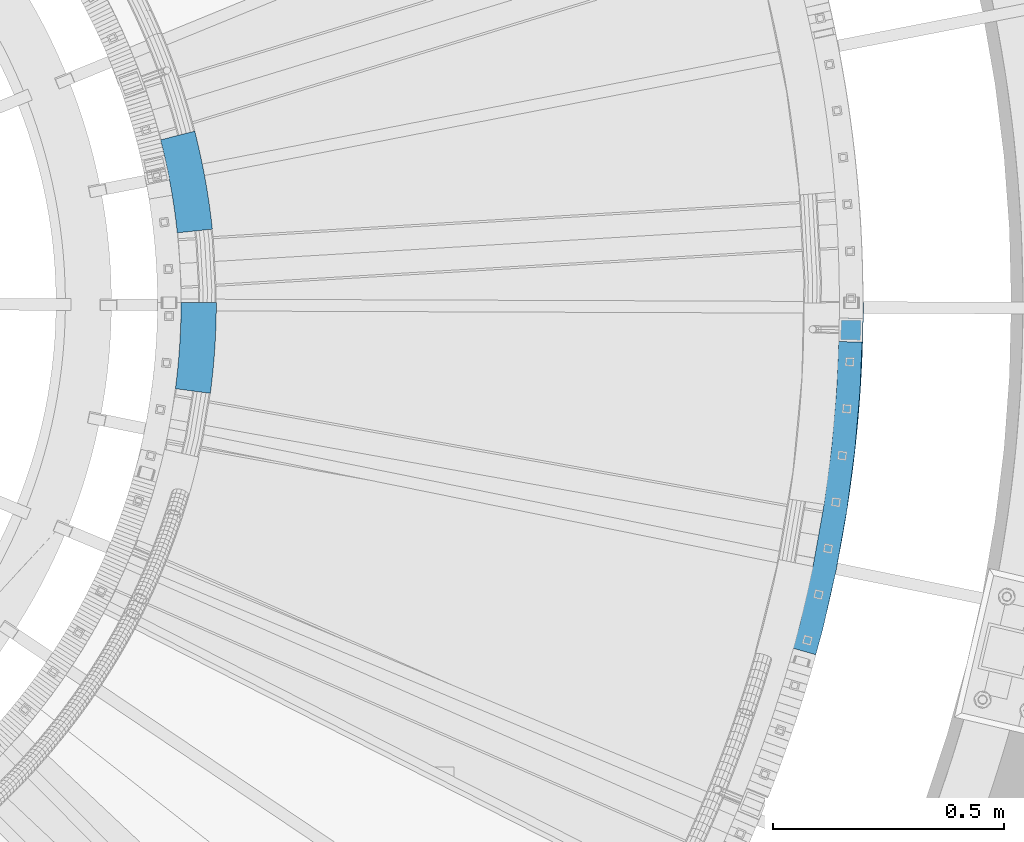
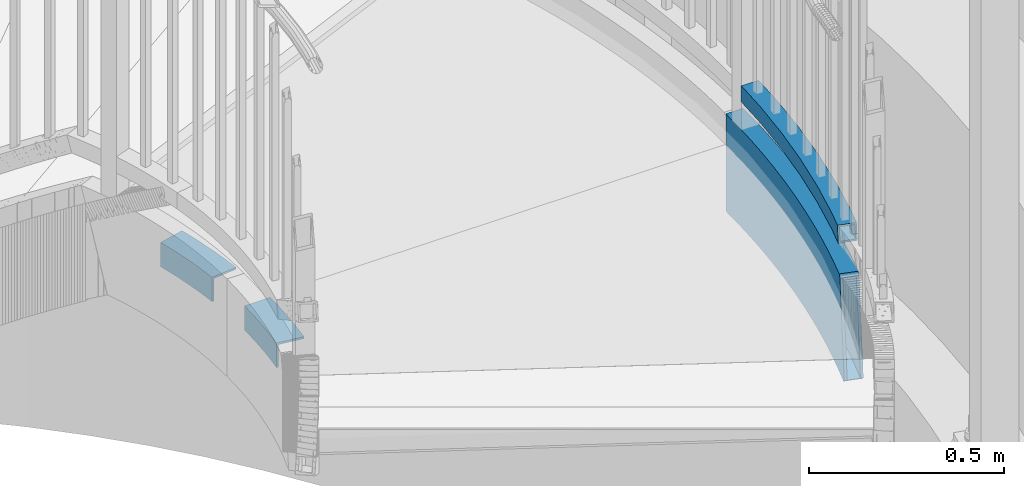
# One storey, part 496 of 975: 4 beams.
"""IFC2X3 building model written with IfcOpenShell, lengths in millimetres."""

from ifc_helpers import new_model, si_unit, frame, origin_with_axes, place, context, subcontext, project, spatial, faceted_brep, material, type_object, element, save


model = new_model("IFC2X3")

# Units and contexts
model_context = context("Model", 3, precision=1e-05, world=origin_with_axes())
body_context = subcontext(model_context, "Body", "Model", "MODEL_VIEW")
ifc_project = project(units=[si_unit("LENGTHUNIT", "METRE", prefix="MILLI"), si_unit("AREAUNIT", "SQUARE_METRE"), si_unit("VOLUMEUNIT", "CUBIC_METRE"), si_unit("MASSUNIT", "GRAM", prefix="KILO"), si_unit("TIMEUNIT", "SECOND"), si_unit("PLANEANGLEUNIT", "RADIAN"), si_unit("SOLIDANGLEUNIT", "STERADIAN"), si_unit("THERMODYNAMICTEMPERATUREUNIT", "DEGREE_CELSIUS"), si_unit("LUMINOUSINTENSITYUNIT", "LUMEN")], contexts=[model_context])

# Site, building, storey
site_placement = place(None, origin_with_axes())
site = spatial("IfcSite", under=ifc_project, at=site_placement, CompositionType="ELEMENT")
building_placement = place(site_placement, origin_with_axes())
building = spatial("IfcBuilding", under=site, at=building_placement, Name="Undefined", CompositionType="ELEMENT")
storey_placement = place(building_placement, origin_with_axes())
storey = spatial("IfcBuildingStorey", under=building, at=storey_placement, Name="Undefined", CompositionType="ELEMENT", Elevation=0.0)

# Beams
ifc_material_1 = material()
beam_type_1 = type_object("IfcBeamType", Name="HSS2X2X.188_TUBES", PredefinedType="NOTDEFINED")
beam_1_placement = place(storey_placement, frame((37604.0922873193, 3344.54176721563, 2298.70000076294), z_axis=(0.0, 0.0, 1.0), x_axis=(-0.243103072953538, -0.970000461814605, 0.0)))
element("IfcBeam", 1, at=beam_1_placement, inside=storey, type_object=beam_type_1, material=ifc_material_1, Name="HANDRAIL", ObjectType="HSS2X2X.188_TUBES", context=body_context, shape_type="Brep", body=[
    faceted_brep([(512.845049756192, 44.7215911390304, 25.4000000000001), (512.845049756192, 44.7215911390304, -25.4000000000001), (640.943749914859, 47.628649427752, -25.4000000000001), (640.943749914859, 47.628649427752, 25.4000000000001), (385.010103648405, 36.0064018784469, 25.4000000000001), (385.010103648405, 36.0064018784469, -25.4000000000001), (257.702122575194, 21.501026140897, 25.4000000000001), (257.702122575194, 21.501026140897, -25.4000000000001), (131.183232504083, 1.23533036223671, 25.4000000000001), (131.183232504083, 1.23533036223671, -25.4000000000001), (30.591520737029, -19.5968903359244, 25.4000000000001), (30.591520737029, -19.5968903359244, -25.4000000000001), (122.012572611658, 51.200708346747, 25.4000000000001), (122.012572611658, 51.200708346747, -25.4000000000001), (19.2597413870353, 29.920926744162, -25.4000000000001), (19.2597413870353, 29.920926744162, 25.4000000000001), (250.807554437984, 71.8309867031421, 25.4000000000001), (250.807554437984, 71.8309867031421, -25.4000000000001), (380.405823119077, 86.5973160904177, 25.4000000000001), (380.405823119077, 86.5973160904177, -25.4000000000001), (510.540537006209, 95.4692927715223, 25.4000000000001), (510.540537006209, 95.4692927715223, -25.4000000000001), (640.943749914872, 98.4286494277039, 25.4000000000001), (640.943749914872, 98.4286494277039, -25.4000000000001), (698.956766133384, 97.1121082021491, 25.4000000000001), (707.21951956619, 96.9245941537447, -25.4000000000001), (705.666751262856, 46.1598325126834, -25.4000000000001), (697.403997830053, 46.3473465610732, 25.4000000000001), (512.629001685882, 49.4791881670753, -20.6374999999998), (512.629001685882, 49.4791881670753, 20.6374999999998), (640.943749914857, 52.3911494277563, 20.6374999999998), (640.943749914857, 52.3911494277563, -20.6374999999998), (384.57845234878, 40.7493000858231, -20.6374999999998), (384.57845234878, 40.7493000858231, 20.6374999999998), (257.055756812331, 26.2194599436116, -20.6374999999998), (257.055756812331, 26.2194599436116, 20.6374999999998), (130.323483139167, 5.91958454828273, -20.6374999999998), (130.323483139167, 5.91958454828273, 20.6374999999998), (29.529166422968, -14.9545949846724, -20.6374999999998), (29.529166422968, -14.9545949846724, 20.6374999999998), (20.3220957010981, 25.2786313929028, -20.6374999999998), (20.3220957010981, 25.2786313929028, 20.6374999999998), (122.872321976574, 46.5164541606937, -20.6374999999998), (122.872321976574, 46.5164541606937, 20.6374999999998), (251.453920200847, 67.1125529004348, -20.6374999999998), (251.453920200847, 67.1125529004348, 20.6374999999998), (380.837474418704, 81.8544178830416, -20.6374999999998), (380.837474418704, 81.8544178830416, 20.6374999999998), (510.75658507652, 90.71169574347, -20.6374999999998), (510.75658507652, 90.71169574347, 20.6374999999998), (640.94374991487, 93.6661494277068, -20.6374999999998), (640.94374991487, 93.6661494277068, 20.6374999999998), (706.299314403424, 92.1829771919365, -20.6374999999998), (699.585827239272, 92.3353323562551, 20.6374999999998), (698.324202992815, 51.0889635228959, 20.6374999999998), (705.037690156971, 50.9366083585701, -20.6374999999998)], [[[0, 1, 2, 3]], [[4, 5, 1, 0]], [[6, 7, 5, 4]], [[8, 9, 7, 6]], [[9, 8, 10, 11]], [[12, 13, 14, 15]], [[13, 12, 16, 17]], [[17, 16, 18, 19]], [[19, 18, 20, 21]], [[21, 20, 22, 23]], [[23, 22, 24, 25]], [[2, 1, 5, 7, 9, 11, 14, 13, 17, 19, 21, 23, 25, 26]], [[3, 2, 26, 27]], [[22, 20, 18, 16, 12, 15, 10, 8, 6, 4, 0, 3, 27, 24]], [[28, 29, 30, 31]], [[32, 33, 29, 28]], [[34, 35, 33, 32]], [[36, 37, 35, 34]], [[37, 36, 38, 39]], [[14, 11, 10, 15], [40, 41, 39, 38]], [[42, 43, 41, 40]], [[43, 42, 44, 45]], [[45, 44, 46, 47]], [[47, 46, 48, 49]], [[49, 48, 50, 51]], [[51, 50, 52, 53]], [[30, 29, 33, 35, 37, 39, 41, 43, 45, 47, 49, 51, 53, 54]], [[31, 30, 54, 55]], [[50, 48, 46, 44, 42, 40, 38, 36, 34, 32, 28, 31, 55, 52]], [[27, 26, 25, 24], [54, 53, 52, 55]]]),
])
ifc_material_2 = material(Name="STEEL/A36")
beam_type_2 = type_object("IfcBeamType", Name="L3X3X1/4", PredefinedType="NOTDEFINED")
beam_2_placement = place(storey_placement, frame((36182.3858247911, 3212.78452840028, 2044.7), z_axis=(0.997821669595168, -0.0659690509732435, 0.0), x_axis=(0.0659690509732434, 0.997821669595168, 0.0)))
element("IfcBeam", 2, at=beam_2_placement, inside=storey, type_object=beam_type_2, material=ifc_material_2, Name="ANGLE", ObjectType="L3X3X1/4", context=body_context, shape_type="Brep", body=[
    faceted_brep([(-2.49492569224822, 38.0999999999999, 38.0182238642665), (-2.49492569224822, 31.75, 38.0182238642665), (17.105177245604, 31.75, 39.175530182576), (17.105177245604, 38.0999999999999, 39.175530182576), (2.07910474354048, 31.75, -31.6818532202233), (2.07910474354048, -38.0999999999999, -31.6818532202233), (20.7653447539642, -38.0999999999999, -30.5785067889374), (20.7653447539642, 31.75, -30.5785067889374), (2.49492569224822, -38.0999999999999, -38.0182238642738), (2.49492569224822, 38.0999999999999, -38.0182238642738), (21.0980872547243, 38.0999999999999, -36.9197828772594), (21.0980872547243, -38.0999999999999, -36.9197828772594), (36.7187641930523, 31.75, 40.075863533988), (36.7187641930523, 38.0999999999999, 40.075863533988), (39.4644400764464, -38.0999999999999, -29.7201518533911), (39.4644400764464, 31.75, -29.7201518533911), (39.7140469749365, 38.0999999999999, -36.0652441613347), (39.7140469749365, -38.0999999999999, -36.0652441613347), (56.3424661748213, 31.75, 40.7190692705772), (56.3424661748213, 38.0999999999999, 40.7190692705772), (58.1731788155776, -38.0999999999999, -29.1069358510067), (58.1731788155776, 31.75, -29.1069358510067), (58.3396072374644, 38.0999999999999, -35.4547544984162), (58.3396072374644, -38.0999999999999, -35.4547544984162), (75.972912478197, 31.75, 41.1050369105433), (75.972912478197, 38.0999999999999, 41.1050369105433), (76.8883474195263, -38.0999999999999, -28.7389641123082), (76.8883474195263, 31.75, -28.7389641123082), (76.971568777828, 38.0999999999999, -35.0884187507472), (76.971568777828, -38.0999999999999, -35.0884187507472), (95.6067312320174, 31.75, 41.2337001572159), (95.6067312320174, 38.0999999999999, 41.2337001572159), (95.6067312320156, -38.0999999999999, -28.6162998428626), (95.6067312320156, 31.75, -28.6162998428626), (95.6067312320156, 38.0999999999999, -34.9662998428757), (95.6067312320156, -38.0999999999999, -34.9662998428757), (115.240549985836, 31.75, 41.1050369104487), (115.240549985836, 38.0999999999999, 41.1050369104487), (114.325115044506, -38.0999999999999, -28.7389641123955), (114.325115044506, 31.75, -28.7389641123955), (114.241893686203, 38.0999999999999, -35.0884187508345), (114.241893686203, -38.0999999999999, -35.0884187508345), (134.870996289212, 31.75, 40.7190692704025), (134.870996289212, 38.0999999999999, 40.7190692704025), (133.040283648454, -38.0999999999999, -29.1069358511668), (133.040283648454, 31.75, -29.1069358511668), (132.873855226568, 38.0999999999999, -35.4547544985835), (132.873855226568, -38.0999999999999, -35.4547544985835), (154.494698270981, 31.75, 40.0758635337334), (154.494698270981, 38.0999999999999, 40.0758635337334), (151.749022387586, -38.0999999999999, -29.7201518536385), (151.749022387586, 31.75, -29.7201518536385), (151.499415489095, 38.0999999999999, -36.0652441615748), (151.499415489095, -38.0999999999999, -36.0652441615748), (174.108285218429, 31.75, 39.1755301822341), (174.108285218429, 38.0999999999999, 39.1755301822341), (170.448117710067, -38.0999999999999, -30.5785067892648), (170.448117710067, 31.75, -30.5785067892648), (170.115375209307, 38.0999999999999, -36.9197828775796), (170.115375209307, -38.0999999999999, -36.9197828775796), (193.708388156281, 38.0999999999999, 38.0182238638445), (188.718536771783, 38.0999999999999, -38.0182238646812), (193.708388156281, 31.75, 38.0182238638445), (189.134357720492, 31.75, -31.681853220638), (189.134357720492, -38.0999999999999, -31.681853220638), (188.718536771783, -38.0999999999999, -38.0182238646812)], [[[0, 1, 2, 3]], [[4, 5, 6, 7]], [[8, 9, 10, 11]], [[8, 5, 4, 1, 0, 9]], [[3, 2, 12, 13]], [[7, 6, 14, 15]], [[11, 10, 16, 17]], [[13, 12, 18, 19]], [[15, 14, 20, 21]], [[17, 16, 22, 23]], [[19, 18, 24, 25]], [[21, 20, 26, 27]], [[23, 22, 28, 29]], [[25, 24, 30, 31]], [[27, 26, 32, 33]], [[29, 28, 34, 35]], [[31, 30, 36, 37]], [[33, 32, 38, 39]], [[35, 34, 40, 41]], [[37, 36, 42, 43]], [[39, 38, 44, 45]], [[41, 40, 46, 47]], [[43, 42, 48, 49]], [[45, 44, 50, 51]], [[47, 46, 52, 53]], [[49, 48, 54, 55]], [[51, 50, 56, 57]], [[53, 52, 58, 59]], [[58, 52, 46, 40, 34, 28, 22, 16, 10, 9, 0, 3, 13, 19, 25, 31, 37, 43, 49, 55, 60, 61]], [[55, 54, 62, 60]], [[54, 48, 42, 36, 30, 24, 18, 12, 2, 1, 4, 7, 15, 21, 27, 33, 39, 45, 51, 57, 63, 62]], [[57, 56, 64, 63]], [[56, 50, 44, 38, 32, 26, 20, 14, 6, 5, 8, 11, 17, 23, 29, 35, 41, 47, 53, 59, 65, 64]], [[59, 58, 61, 65]], [[62, 63, 64, 65, 61, 60]]]),
])
beam_3_placement = place(storey_placement, frame((36186.6239028408, 3558.5509998944, 2044.7), z_axis=(0.984193136972033, 0.177098472994967, 0.0), x_axis=(-0.177098472994967, 0.984193136972033, 0.0)))
element("IfcBeam", 3, at=beam_3_placement, inside=storey, type_object=beam_type_2, material=ifc_material_2, Name="ANGLE", ObjectType="L3X3X1/4", context=body_context, shape_type="Brep", body=[
    faceted_brep([(-2.73671066615134, 38.0999999999999, 38.0015843714209), (-2.73671066615134, 31.75, 38.0015843714209), (18.7586199473444, 31.75, 39.3943285454152), (18.7586199473444, 38.0999999999999, 39.3943285454152), (2.28059222179581, 31.75, -31.6679869761792), (2.28059222179581, -38.0999999999999, -31.6679869761792), (22.7737075112873, -38.0999999999999, -30.3401792099467), (22.7737075112873, 31.75, -30.3401792099467), (2.73671066615498, -38.0999999999999, -38.0015843714136), (2.73671066615498, 38.0999999999999, -38.0015843714136), (23.1387154716467, 38.0999999999999, -36.6796799149743), (23.1387154716467, -38.0999999999999, -36.6796799149743), (40.2717532976203, 31.75, 40.4778727166195), (40.2717532976203, 38.0999999999999, 40.4778727166195), (43.2837954886527, -38.0999999999999, -29.3071550606037), (43.2837954886527, 31.75, -29.3071550606037), (43.5576175060196, 38.0999999999999, -35.6512484948908), (43.5576175060196, -38.0999999999999, -35.6512484948908), (61.7982419218315, 31.75, 41.2519928813053), (61.7982419218315, 38.0999999999999, 41.2519928813053), (63.8066160530816, -38.0999999999999, -28.5691280877727), (63.8066160530816, 31.75, -28.5691280877727), (63.9891955195581, 38.0999999999999, -34.9165027213312), (63.9891955195581, -38.0999999999999, -34.9165027213312), (83.3336355961674, 31.75, 41.7165290036937), (83.3336355961674, 38.0999999999999, 41.7165290036937), (84.337926471524, -38.0999999999999, -28.1262508655782), (84.337926471524, 31.75, -28.1262508655782), (84.4292256420085, 38.0999999999999, -34.4755944900608), (84.4292256420085, -38.0999999999999, -34.4755944900608), (104.873482255854, 31.75, 41.8713850490967), (104.873482255854, 38.0999999999999, 41.8713850490967), (104.873482255798, -38.0999999999999, -27.9786149511201), (104.873482255798, 31.75, -27.9786149511201), (104.873482255793, 38.0999999999999, -34.3286149511332), (104.873482255793, -38.0999999999999, -34.3286149511332), (126.41332891554, 31.75, 41.7165290037519), (126.41332891554, 38.0999999999999, 41.7165290037519), (125.409038040074, -38.0999999999999, -28.12625086552), (125.409038040074, 31.75, -28.12625086552), (125.317738869575, 38.0999999999999, -34.4755944900025), (125.317738869575, -38.0999999999999, -34.4755944900025), (147.948722589874, 31.75, 41.2519928814218), (147.948722589874, 38.0999999999999, 41.2519928814218), (145.940348458515, -38.0999999999999, -28.5691280876563), (145.940348458515, 31.75, -28.5691280876563), (145.757768992025, 38.0999999999999, -34.9165027212002), (145.757768992025, -38.0999999999999, -34.9165027212002), (169.475211214081, 31.75, 40.4778727168086), (169.475211214081, 38.0999999999999, 40.4778727168086), (166.463169022942, -38.0999999999999, -29.3071550604291), (166.463169022942, 31.75, -29.3071550604291), (166.189347005566, 38.0999999999999, -35.6512484947234), (166.189347005566, -38.0999999999999, -35.6512484947234), (190.988344564355, 31.75, 39.3943285456626), (190.988344564355, 38.0999999999999, 39.3943285456626), (186.973257000305, -38.0999999999999, -30.3401792097065), (186.973257000305, 31.75, -30.3401792097065), (186.608249039937, 38.0999999999999, -36.6796799147414), (186.608249039937, -38.0999999999999, -36.6796799147414), (212.483675177849, 38.0999999999999, 38.0015843717338), (207.010253845423, 38.0999999999999, -38.0015843711153), (212.483675177849, 31.75, 38.0015843717338), (207.466372289793, 31.75, -31.6679869758736), (207.466372289793, -38.0999999999999, -31.6679869758736), (207.010253845423, -38.0999999999999, -38.0015843711153)], [[[0, 1, 2, 3]], [[4, 5, 6, 7]], [[8, 9, 10, 11]], [[8, 5, 4, 1, 0, 9]], [[3, 2, 12, 13]], [[7, 6, 14, 15]], [[11, 10, 16, 17]], [[13, 12, 18, 19]], [[15, 14, 20, 21]], [[17, 16, 22, 23]], [[19, 18, 24, 25]], [[21, 20, 26, 27]], [[23, 22, 28, 29]], [[25, 24, 30, 31]], [[27, 26, 32, 33]], [[29, 28, 34, 35]], [[31, 30, 36, 37]], [[33, 32, 38, 39]], [[35, 34, 40, 41]], [[37, 36, 42, 43]], [[39, 38, 44, 45]], [[41, 40, 46, 47]], [[43, 42, 48, 49]], [[45, 44, 50, 51]], [[47, 46, 52, 53]], [[49, 48, 54, 55]], [[51, 50, 56, 57]], [[53, 52, 58, 59]], [[58, 52, 46, 40, 34, 28, 22, 16, 10, 9, 0, 3, 13, 19, 25, 31, 37, 43, 49, 55, 60, 61]], [[55, 54, 62, 60]], [[54, 48, 42, 36, 30, 24, 18, 12, 2, 1, 4, 7, 15, 21, 27, 33, 39, 45, 51, 57, 63, 62]], [[57, 56, 64, 63]], [[56, 50, 44, 38, 32, 26, 20, 14, 6, 5, 8, 11, 17, 23, 29, 35, 41, 47, 53, 59, 65, 64]], [[59, 58, 61, 65]], [[62, 63, 64, 65, 61, 60]]]),
])
beam_type_3 = type_object("IfcBeamType", Name="HSS12X2X5/16", PredefinedType="NOTDEFINED")
beam_4_placement = place(storey_placement, frame((37376.4468906606, 4525.99145392499, 2031.99999923706), z_axis=(0.0, 0.0, 1.0), x_axis=(0.0625371900182985, -0.99804263429205, 0.0)))
element("IfcBeam", 4, at=beam_4_placement, inside=storey, type_object=beam_type_3, material=ifc_material_1, Name="STAIR", ObjectType="HSS12X2X5/16", context=body_context, shape_type="Brep", body=[
    faceted_brep([(1914.55648496556, 16.4537418526961, 120.255085981103), (1945.24588025799, 5.34665021121327, -85.841566583689), (1953.93986757041, 2.08770848040149, -144.4625), (1956.58595101678, 9.5725224903581, -144.517334059184), (1947.98958988467, 12.7948690408957, -86.554664522223), (1917.21521785555, 23.9327154233251, 120.112654906821), (1913.57462518644, 25.2032345344487, 144.462500023935), (1910.93718741852, 17.7168292455099, 144.4625), (1906.0707504027, 27.8219884538776, 152.4), (1889.19114881581, -20.0910054405103, 152.4), (1896.69502360485, -22.7097593616927, 144.462500007008), (1899.33246134898, -15.2233540643574, 144.4625), (1947.98958988467, 12.7948690408957, -152.4), (1949.20335250547, 12.3398900405664, -152.4), (1838.33942852959, -2.74534963287442, 152.4), (1838.33942852959, -2.74534963287442, -152.4), (1869.330707284, -13.1599717279169, -152.4), (1869.330707284, -13.1599717279169, 152.4), (1807.22964568064, 7.30975470804697, 152.4), (1807.22964568064, 7.30975470804697, -152.4), (1776.00552920763, 17.0039933421795, 152.4), (1776.00552920763, 17.0039933421795, -152.4), (1744.6712649082, 26.3360666932203, 152.4), (1744.6712649082, 26.3360666932203, -152.4), (1713.23105334605, 35.3047237355131, 152.4), (1713.23105334605, 35.3047237355131, -152.4), (1681.68910928777, 43.9087621617582, 152.4), (1681.68910928777, 43.9087621617582, -152.4), (1650.04966113791, 52.147028544161, 152.4), (1650.04966113791, 52.147028544161, -152.4), (1618.31695037203, 60.0184184890531, 152.4), (1618.31695037203, 60.0184184890531, -152.4), (1586.4952309682, 67.5218767849801, 152.4), (1586.4952309682, 67.5218767849801, -152.4), (1554.58876883664, 74.6563975441386, 152.4), (1554.58876883664, 74.6563975441386, -152.4), (1522.60184124793, 81.4210243372145, 152.4), (1522.60184124793, 81.4210243372145, -152.4), (1490.53873625955, 87.8148503216216, 152.4), (1490.53873625955, 87.8148503216216, -152.4), (1458.40375214105, 93.837018363025, 152.4), (1458.40375214105, 93.837018363025, -152.4), (1426.20119679787, 99.4867211502933, 152.4), (1426.20119679787, 99.4867211502933, -152.4), (1393.93538719381, 104.763201303715, 152.4), (1393.93538719381, 104.763201303715, -152.4), (1361.61064877232, 109.665751476503, 152.4), (1361.61064877232, 109.665751476503, -152.4), (1329.23131487663, 114.193714449648, 152.4), (1329.23131487663, 114.193714449648, -152.4), (1296.80172616887, 118.346483220012, 152.4), (1296.80172616887, 118.346483220012, -152.4), (1264.32623004815, 122.123501081689, 152.4), (1264.32623004815, 122.123501081689, -152.4), (1231.80918006776, 125.524261700673, 152.4), (1231.80918006776, 125.524261700673, -152.4), (1199.25493535158, 128.548309182675, 152.4), (1199.25493535158, 128.548309182675, -152.4), (1166.66786000967, 131.195238134314, 152.4), (1166.66786000967, 131.195238134314, -152.4), (1134.05232255326, 133.464693717367, 152.4), (1134.05232255326, 133.464693717367, -152.4), (1132.9595377116, 133.528027682718, 152.4), (1132.9595377116, 133.528027682718, -152.4), (1854.24245117133, 45.5012447637127, -152.4), (1854.24245117133, 45.5012447637127, 152.4), (1885.79126717584, 34.8992622241567, 152.4), (1885.79126717584, 34.8992622241567, -152.4), (1822.57299916776, 55.7372417766746, -152.4), (1822.57299916776, 55.7372417766746, 152.4), (1790.78715666294, 65.60588106051, -152.4), (1790.78715666294, 65.60588106051, 152.4), (1758.88918475758, 75.1058396593726, -152.4), (1758.88918475758, 75.1058396593726, 152.4), (1726.88335958406, 84.2358440414828, -152.4), (1726.88335958406, 84.2358440414828, 152.4), (1694.77397173321, 92.9946702698653, -152.4), (1694.77397173321, 92.9946702698653, 152.4), (1662.56532567912, 101.381144166415, -152.4), (1662.56532567912, 101.381144166415, 152.4), (1630.26173920209, 109.394141469274, -152.4), (1630.26173920209, 109.394141469274, 152.4), (1597.86754280978, 117.032587983587, -152.4), (1597.86754280978, 117.032587983587, 152.4), (1565.38707915676, 124.295459725501, -152.4), (1565.38707915676, 124.295459725501, 152.4), (1532.82470246224, 131.181783059408, -152.4), (1532.82470246224, 131.181783059408, 152.4), (1500.18477792644, 137.69063482849, -152.4), (1500.18477792644, 137.69063482849, 152.4), (1467.47168114536, 143.82114247846, -152.4), (1467.47168114536, 143.82114247846, 152.4), (1434.68979752423, 149.572484174569, -152.4), (1434.68979752423, 149.572484174569, 152.4), (1401.84352168961, 154.943888911723, -152.4), (1401.84352168961, 154.943888911723, 152.4), (1368.93725690024, 159.934636617872, -152.4), (1368.93725690024, 159.934636617872, 152.4), (1335.97541445679, 164.544058250547, -152.4), (1335.97541445679, 164.544058250547, 152.4), (1302.96241311048, 168.771535886561, -152.4), (1302.96241311048, 168.771535886561, 152.4), (1269.90267847071, 172.616502804762, -152.4), (1269.90267847071, 172.616502804762, 152.4), (1236.80064241179, 176.078443562161, -152.4), (1236.80064241179, 176.078443562161, 152.4), (1203.66074247879, 179.156894062864, -152.4), (1203.66074247879, 179.156894062864, 152.4), (1170.48742129272, 181.851441620369, -152.4), (1170.48742129272, 181.851441620369, 152.4), (1137.2851259549, 184.161725012935, -152.4), (1137.2851259549, 184.161725012935, 152.4), (1136.13640861289, 184.228300629249, -152.4), (1136.13640861289, 184.228300629249, 152.4), (1840.82427581736, 4.793180741588, -144.4625), (1840.82427581736, 4.793180741588, 144.4625), (1871.9026697671, -5.65071642290422, 144.4625), (1871.9026697671, -5.65071642290422, -144.4625), (1809.62704466301, 14.8765495625194, -144.4625), (1809.62704466301, 14.8765495625194, 144.4625), (1778.31515849752, 24.5980382981725, -144.4625), (1778.31515849752, 24.5980382981725, 144.4625), (1746.89281488467, 33.9563437191828, -144.4625), (1746.89281488467, 33.9563437191828, 144.4625), (1715.36422619574, 42.9502112833288, -144.4625), (1715.36422619574, 42.9502112833288, 144.4625), (1683.73361904487, 51.5784353036506, -144.4625), (1683.73361904487, 51.5784353036506, 144.4625), (1652.00523372247, 59.8398591101286, -144.4625), (1652.00523372247, 59.8398591101286, 144.4625), (1620.18332362673, 67.7333752047052, -144.4625), (1620.18332362673, 67.7333752047052, 144.4625), (1588.27215469344, 75.2579254097582, -144.4625), (1588.27215469344, 75.2579254097582, 144.4625), (1556.27600482416, 82.4125010099815, -144.4625), (1556.27600482416, 82.4125010099815, 144.4625), (1524.19916331267, 89.1961428875657, -144.4625), (1524.19916331267, 89.1961428875657, 144.4625), (1492.04593027, 95.6079416508219, -144.4625), (1492.04593027, 95.6079416508219, 144.4625), (1459.82061604797, 101.647037756062, -144.4625), (1459.82061604797, 101.647037756062, 144.4625), (1427.52754066137, 107.312621622834, -144.4625), (1427.52754066137, 107.312621622834, 144.4625), (1395.17103320878, 112.603933742466, -144.4625), (1395.17103320878, 112.603933742466, 144.4625), (1362.75543129231, 117.520264779843, -144.4625), (1362.75543129231, 117.520264779843, 144.4625), (1330.28508043603, 122.060955668538, -144.4625), (1330.28508043603, 122.060955668538, 144.4625), (1297.7643335035, 126.225397699163, -144.4625), (1297.7643335035, 126.225397699163, 144.4625), (1265.19755011417, 130.013032600924, -144.4625), (1265.19755011417, 130.013032600924, 144.4625), (1232.58909605902, 133.423352616534, -144.4625), (1232.58909605902, 133.423352616534, 144.4625), (1199.94334271521, 136.45590057021, -144.4625), (1199.94334271521, 136.45590057021, 144.4625), (1167.26466646015, 139.110269929006, -144.4625), (1167.26466646015, 139.110269929006, 144.4625), (1134.55744808476, 141.386104857302, -144.4625), (1134.55744808476, 141.386104857302, 144.4625), (1133.45592378993, 141.449945330613, -144.4625), (1133.45592378993, 141.449945330613, 144.4625), (1135.64002253457, 176.306382981355, -144.4625), (1135.64002253457, 176.306382981355, 144.4625), (1136.78000042339, 176.240313872993, -144.4625), (1136.78000042339, 176.240313872993, 144.4625), (1169.89061484224, 173.936409825677, -144.4625), (1169.89061484224, 173.936409825677, 144.4625), (1202.97233511517, 171.249302675329, -144.4625), (1202.97233511517, 171.249302675329, 144.4625), (1236.02072642053, 168.179352646301, -144.4625), (1236.02072642053, 168.179352646301, 144.4625), (1269.03135840469, 164.726971285541, -144.4625), (1269.03135840469, 164.726971285541, 144.4625), (1301.99980577586, 160.892621407409, -144.4625), (1301.99980577586, 160.892621407409, 144.4625), (1334.92164889739, 156.676817031657, -144.4625), (1334.92164889739, 156.676817031657, 144.4625), (1367.79247438025, 152.080123314532, -144.4625), (1367.79247438025, 152.080123314532, 144.4625), (1400.60787567464, 147.103156472964, -144.4625), (1400.60787567464, 147.103156472964, 144.4625), (1433.36345366074, 141.746583702021, -144.4625), (1433.36345366074, 141.746583702021, 144.4625), (1466.05481723844, 136.011123085424, -144.4625), (1466.05481723844, 136.011123085424, 144.4625), (1498.67758391599, 129.897543499297, -144.4625), (1498.67758391599, 129.897543499297, 144.4625), (1531.22738039751, 123.406664509072, -144.4625), (1531.22738039751, 123.406664509072, 144.4625), (1563.69984316924, 116.539356259666, -144.4625), (1563.69984316924, 116.539356259666, 144.4625), (1596.09061908454, 109.296539358809, -144.4625), (1596.09061908454, 109.296539358809, 144.4625), (1628.39536594739, 101.679184753608, -144.4625), (1628.39536594739, 101.679184753608, 144.4625), (1660.60975309456, 93.6883136004326, -144.4625), (1660.60975309456, 93.6883136004326, 144.4625), (1692.72946197611, 85.3249971279729, -144.4625), (1692.72946197611, 85.3249971279729, 144.4625), (1724.75018673437, 76.5903564936816, -144.4625), (1724.75018673437, 76.5903564936816, 144.4625), (1756.66763478111, 67.4855626334102, -144.4625), (1756.66763478111, 67.4855626334102, 144.4625), (1788.47752737305, 58.0118361045243, -144.4625), (1788.47752737305, 58.0118361045243, 144.4625), (1820.1756001854, 48.1704469222168, -144.4625), (1820.1756001854, 48.1704469222168, 144.4625), (1851.75760388355, 37.9627143892503, -144.4625), (1851.75760388355, 37.9627143892503, 144.4625), (1883.21930469274, 27.3900069191441, -144.4625), (1883.21930469274, 27.3900069191441, 144.4625), (1945.24588025799, 5.34665021121327, -144.4625), (1914.55648496556, 16.4537418526961, -144.4625), (1902.85806024963, -16.4537418580294, -144.4625), (1902.85806024963, -16.4537418580294, 120.881782707944), (1933.17355790063, -27.4255126393837, -144.4625), (1933.17355790063, -27.4255126393837, -82.7039356541495), (1942.33288279645, -30.8588861947355, -144.4625), (1900.19932735965, -23.9327154286439, -152.4), (1930.42984827396, -34.8737314690661, -152.4), (1930.42984827396, -34.8737314690661, -81.9908377156141), (1900.19932735965, -23.9327154286439, 121.024213782227), (1932.32046557942, -35.5824294936101, -152.4), (1939.70306407528, -38.3497970380267, -144.517334075679), (1917.21521785555, 23.9327154233251, -152.4)], [[[0, 1, 2, 3, 4, 5, 6, 7]], [[6, 8, 9, 10, 11, 7]], [[12, 4, 3, 13]], [[14, 15, 16, 17]], [[18, 19, 15, 14]], [[20, 21, 19, 18]], [[22, 23, 21, 20]], [[24, 25, 23, 22]], [[26, 27, 25, 24]], [[28, 29, 27, 26]], [[30, 31, 29, 28]], [[32, 33, 31, 30]], [[34, 35, 33, 32]], [[36, 37, 35, 34]], [[38, 39, 37, 36]], [[40, 41, 39, 38]], [[42, 43, 41, 40]], [[44, 45, 43, 42]], [[46, 47, 45, 44]], [[48, 49, 47, 46]], [[50, 51, 49, 48]], [[52, 53, 51, 50]], [[54, 55, 53, 52]], [[56, 57, 55, 54]], [[58, 59, 57, 56]], [[60, 61, 59, 58]], [[61, 60, 62, 63]], [[64, 65, 66, 67]], [[68, 69, 65, 64]], [[70, 71, 69, 68]], [[72, 73, 71, 70]], [[74, 75, 73, 72]], [[76, 77, 75, 74]], [[78, 79, 77, 76]], [[80, 81, 79, 78]], [[82, 83, 81, 80]], [[84, 85, 83, 82]], [[86, 87, 85, 84]], [[88, 89, 87, 86]], [[90, 91, 89, 88]], [[92, 93, 91, 90]], [[94, 95, 93, 92]], [[96, 97, 95, 94]], [[98, 99, 97, 96]], [[100, 101, 99, 98]], [[102, 103, 101, 100]], [[104, 105, 103, 102]], [[106, 107, 105, 104]], [[108, 109, 107, 106]], [[110, 111, 109, 108]], [[111, 110, 112, 113]], [[114, 115, 116, 117]], [[118, 119, 115, 114]], [[120, 121, 119, 118]], [[122, 123, 121, 120]], [[124, 125, 123, 122]], [[126, 127, 125, 124]], [[128, 129, 127, 126]], [[130, 131, 129, 128]], [[132, 133, 131, 130]], [[134, 135, 133, 132]], [[136, 137, 135, 134]], [[138, 139, 137, 136]], [[140, 141, 139, 138]], [[142, 143, 141, 140]], [[144, 145, 143, 142]], [[146, 147, 145, 144]], [[148, 149, 147, 146]], [[150, 151, 149, 148]], [[152, 153, 151, 150]], [[154, 155, 153, 152]], [[156, 157, 155, 154]], [[158, 159, 157, 156]], [[160, 161, 159, 158]], [[161, 160, 162, 163]], [[63, 62, 113, 112], [162, 164, 165, 163]], [[166, 167, 165, 164]], [[167, 166, 168, 169]], [[169, 168, 170, 171]], [[171, 170, 172, 173]], [[173, 172, 174, 175]], [[175, 174, 176, 177]], [[177, 176, 178, 179]], [[179, 178, 180, 181]], [[181, 180, 182, 183]], [[183, 182, 184, 185]], [[185, 184, 186, 187]], [[187, 186, 188, 189]], [[189, 188, 190, 191]], [[191, 190, 192, 193]], [[193, 192, 194, 195]], [[195, 194, 196, 197]], [[197, 196, 198, 199]], [[199, 198, 200, 201]], [[201, 200, 202, 203]], [[203, 202, 204, 205]], [[205, 204, 206, 207]], [[207, 206, 208, 209]], [[209, 208, 210, 211]], [[211, 210, 212, 213]], [[214, 2, 1]], [[215, 214, 1, 0]], [[213, 212, 215, 0, 7]], [[116, 115, 119, 121, 123, 125, 127, 129, 131, 133, 135, 137, 139, 141, 143, 145, 147, 149, 151, 153, 155, 157, 159, 161, 163, 165, 167, 169, 171, 173, 175, 177, 179, 181, 183, 185, 187, 189, 191, 193, 195, 197, 199, 201, 203, 205, 207, 209, 211, 213, 7, 11]], [[216, 117, 116, 11, 217]], [[218, 216, 217, 219]], [[218, 219, 220]], [[214, 215, 212, 210, 208, 206, 204, 202, 200, 198, 196, 194, 192, 190, 188, 186, 184, 182, 180, 178, 176, 174, 172, 170, 168, 166, 164, 162, 160, 158, 156, 154, 152, 150, 148, 146, 144, 142, 140, 138, 136, 134, 132, 130, 128, 126, 124, 122, 120, 118, 114, 117, 216, 218, 220, 2]], [[221, 222, 223, 224]], [[223, 222, 225, 226]], [[3, 2, 220, 226, 225, 13]], [[222, 221, 16, 15, 19, 21, 23, 25, 27, 29, 31, 33, 35, 37, 39, 41, 43, 45, 47, 49, 51, 53, 55, 57, 59, 61, 63, 112, 110, 108, 106, 104, 102, 100, 98, 96, 94, 92, 90, 88, 86, 84, 82, 80, 78, 76, 74, 72, 70, 68, 64, 67, 227, 12, 13, 225]], [[12, 227, 5, 4]], [[224, 223, 226, 220, 219, 217, 11, 10]], [[17, 16, 221, 224, 10, 9]], [[66, 65, 69, 71, 73, 75, 77, 79, 81, 83, 85, 87, 89, 91, 93, 95, 97, 99, 101, 103, 105, 107, 109, 111, 113, 62, 60, 58, 56, 54, 52, 50, 48, 46, 44, 42, 40, 38, 36, 34, 32, 30, 28, 26, 24, 22, 20, 18, 14, 17, 9, 8]], [[5, 227, 67, 66, 8, 6]]]),
])

save(model, "model.ifc")
